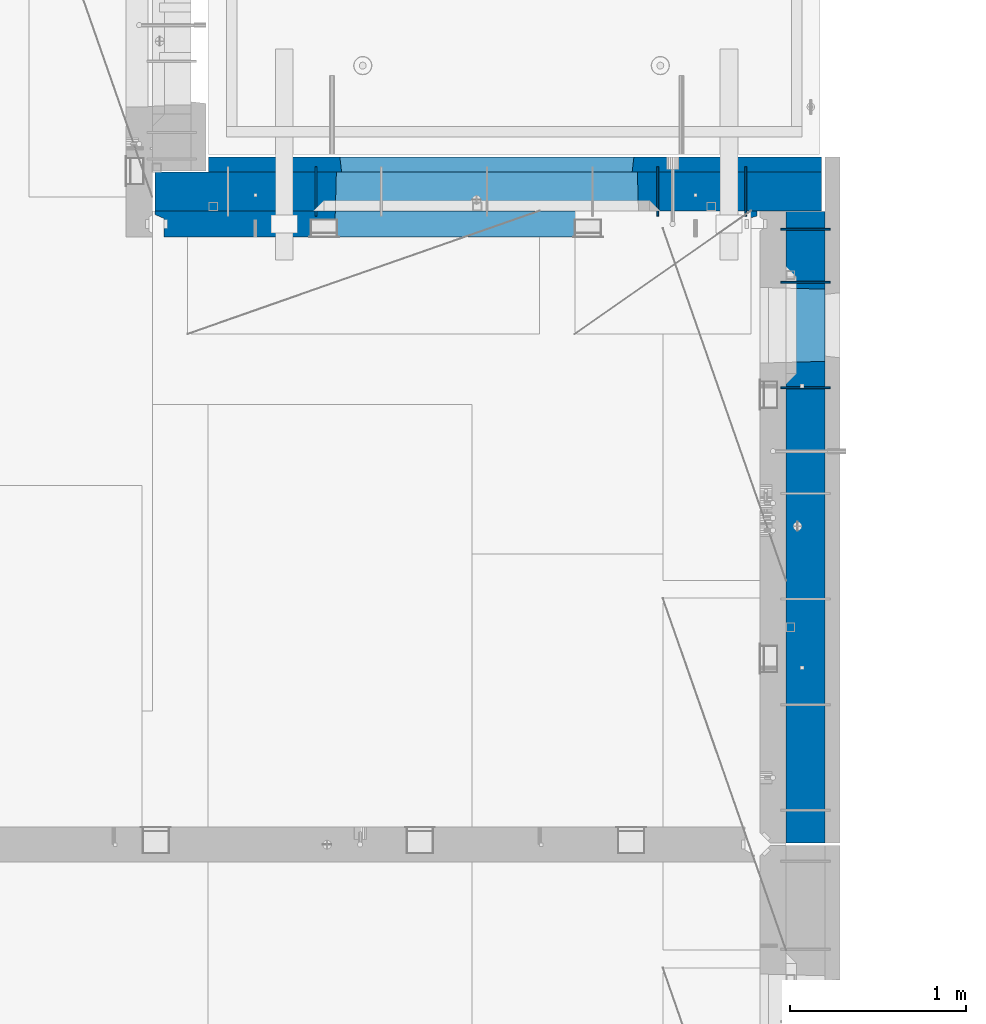
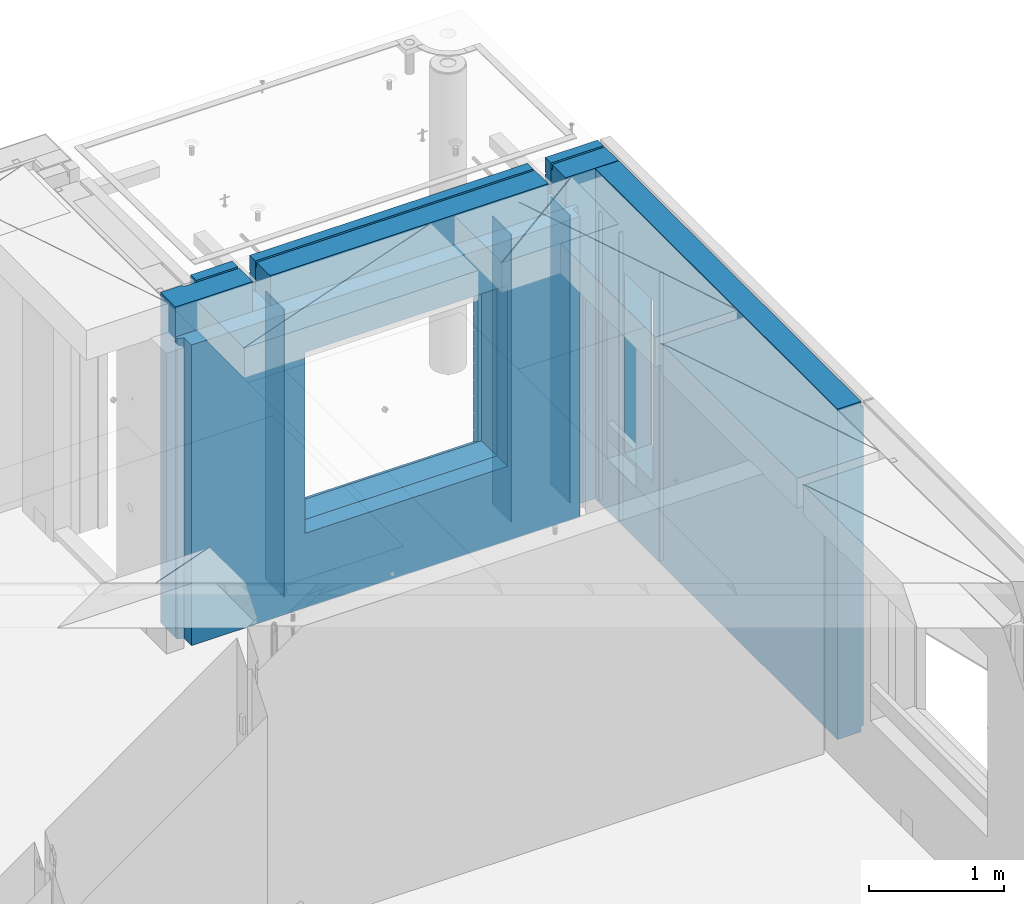
# One storey, part 222 of 325: 10 walls, 2 elements without a shape of their own.
"""IFC2X3 building model written with IfcOpenShell, lengths in millimetres."""

from ifc_helpers import new_model, si_unit, frame, origin_with_axes, place, context, subcontext, project, spatial, faceted_brep, material, type_object, element, aggregate, save


model = new_model("IFC2X3")

# Units and contexts
model_context = context("Model", 3, precision=1e-05, world=origin_with_axes())
body_context = subcontext(model_context, "Body", "Model", "MODEL_VIEW")
ifc_project = project(units=[si_unit("LENGTHUNIT", "METRE", prefix="MILLI"), si_unit("AREAUNIT", "SQUARE_METRE"), si_unit("VOLUMEUNIT", "CUBIC_METRE"), si_unit("MASSUNIT", "GRAM", prefix="KILO"), si_unit("TIMEUNIT", "SECOND"), si_unit("PLANEANGLEUNIT", "RADIAN"), si_unit("SOLIDANGLEUNIT", "STERADIAN"), si_unit("THERMODYNAMICTEMPERATUREUNIT", "DEGREE_CELSIUS"), si_unit("LUMINOUSINTENSITYUNIT", "LUMEN")], contexts=[model_context])

# Site, building, storey
site_placement = place(None, origin_with_axes())
site = spatial("IfcSite", under=ifc_project, at=site_placement, CompositionType="ELEMENT")
building_placement = place(site_placement, origin_with_axes())
building = spatial("IfcBuilding", under=site, at=building_placement, CompositionType="ELEMENT")
storey_placement = place(building_placement, origin_with_axes())
storey = spatial("IfcBuildingStorey", under=building, at=storey_placement, Name="1", CompositionType="ELEMENT", Elevation=0.0)

# Assembly, walls
assembly_1_placement = place(storey_placement, origin_with_axes())
assembly_1 = element("IfcElementAssembly", 1, at=assembly_1_placement, inside=storey, AssemblyPlace="NOTDEFINED", PredefinedType="REINFORCEMENT_UNIT")
ifc_material_1 = material(Name="Undefined")
wall_type_1 = type_object("IfcWallType", PredefinedType="NOTDEFINED")
wall_1_placement = place(assembly_1_placement, frame((34830.0, 20549.9951872276, 83115.0), z_axis=(0.0, 0.0, 1.0), x_axis=(0.0, 1.0, 0.0)))
wall_1 = element("IfcWall", 2, at=wall_1_placement, type_object=wall_type_1, material=ifc_material_1, Name="(PD)", context=body_context, shape_type="Brep", body=[
    faceted_brep([(0.0, 5.0, -1300.0), (0.0, 5.0, 1300.0), (280.0, 5.0, 1300.0), (280.0, 5.0, -1300.0), (0.0, -5.0, 1300.0), (280.0, -5.0, 1300.0), (0.0, -5.0, -1300.0), (280.0, -5.0, -1300.0)], [[[0, 1, 2, 3]], [[1, 4, 5, 2]], [[4, 6, 7, 5]], [[6, 0, 3, 7]], [[5, 7, 3, 2]], [[6, 4, 1, 0]]]),
])
wall_2_placement = place(assembly_1_placement, frame((34330.0, 20549.9951872276, 83115.0), z_axis=(0.0, 0.0, 1.0), x_axis=(0.0, 1.0, 0.0)))
wall_2 = element("IfcWall", 3, at=wall_2_placement, type_object=wall_type_1, material=ifc_material_1, Name="(PD)", context=body_context, shape_type="Brep", body=[
    faceted_brep([(0.0, 5.0, -1300.0), (0.0, 5.0, 1300.0), (280.0, 5.0, 1300.0), (280.0, 5.0, -1300.0), (0.0, -5.0, 1300.0), (280.0, -5.0, 1300.0), (0.0, -5.0, -1300.0), (280.0, -5.0, -1300.0)], [[[0, 1, 2, 3]], [[1, 4, 5, 2]], [[4, 6, 7, 5]], [[6, 0, 3, 7]], [[5, 7, 3, 2]], [[6, 4, 1, 0]]]),
])
wall_3_placement = place(assembly_1_placement, frame((32390.0, 20549.9951872276, 83115.0), z_axis=(0.0, 0.0, 1.0), x_axis=(0.0, 1.0, 0.0)))
wall_3 = element("IfcWall", 4, at=wall_3_placement, type_object=wall_type_1, material=ifc_material_1, Name="(PD)", context=body_context, shape_type="Brep", body=[
    faceted_brep([(0.0, 5.0, -1300.0), (0.0, 5.0, 1300.0), (280.0, 5.0, 1300.0), (280.0, 5.0, -1300.0), (0.0, -5.0, 1300.0), (280.0, -5.0, 1300.0), (0.0, -5.0, -1300.0), (280.0, -5.0, -1300.0)], [[[0, 1, 2, 3]], [[1, 4, 5, 2]], [[4, 6, 7, 5]], [[6, 0, 3, 7]], [[5, 7, 3, 2]], [[6, 4, 1, 0]]]),
])

assembly_2_placement = place(storey_placement, origin_with_axes())
assembly_2 = element("IfcElementAssembly", 5, at=assembly_2_placement, inside=storey, AssemblyPlace="NOTDEFINED", PredefinedType="REINFORCEMENT_UNIT")
wall_4_placement = place(assembly_2_placement, frame((35030.0, 20175.0002441406, 83115.0), z_axis=(0.0, 0.0, 1.0), x_axis=(1.0, 0.0, 0.0)))
wall_4 = element("IfcWall", 6, at=wall_4_placement, type_object=wall_type_1, material=ifc_material_1, Name="(PD)", context=body_context, shape_type="Brep", body=[
    faceted_brep([(0.0, 5.0, -1300.0), (0.0, 5.0, 1300.0), (280.0, 5.0, 1300.0), (280.0, 5.0, -1300.0), (0.0, -5.0, 1300.0), (280.0, -5.0, 1300.0), (0.0, -5.0, -1300.0), (280.0, -5.0, -1300.0)], [[[0, 1, 2, 3]], [[1, 4, 5, 2]], [[4, 6, 7, 5]], [[6, 0, 3, 7]], [[5, 7, 3, 2]], [[6, 4, 1, 0]]]),
])
wall_5_placement = place(assembly_2_placement, frame((35030.0, 20475.0002441406, 83115.0), z_axis=(0.0, 0.0, 1.0), x_axis=(1.0, 0.0, 0.0)))
wall_5 = element("IfcWall", 7, at=wall_5_placement, type_object=wall_type_1, material=ifc_material_1, Name="(PD)", context=body_context, shape_type="Brep", body=[
    faceted_brep([(0.0, 5.0, -1300.0), (0.0, 5.0, 1300.0), (280.0, 5.0, 1300.0), (280.0, 5.0, -1300.0), (0.0, -5.0, 1300.0), (280.0, -5.0, 1300.0), (0.0, -5.0, -1300.0), (280.0, -5.0, -1300.0)], [[[0, 1, 2, 3]], [[1, 4, 5, 2]], [[4, 6, 7, 5]], [[6, 0, 3, 7]], [[5, 7, 3, 2]], [[6, 4, 1, 0]]]),
])
wall_6_placement = place(assembly_2_placement, frame((35030.0, 19575.0002441406, 83115.0), z_axis=(0.0, 0.0, 1.0), x_axis=(1.0, 0.0, 0.0)))
wall_6 = element("IfcWall", 8, at=wall_6_placement, type_object=wall_type_1, material=ifc_material_1, Name="(PD)", context=body_context, shape_type="Brep", body=[
    faceted_brep([(0.0, 5.0, -1300.0), (0.0, 5.0, 1300.0), (280.0, 5.0, 1300.0), (280.0, 5.0, -1300.0), (0.0, -5.0, 1300.0), (280.0, -5.0, 1300.0), (0.0, -5.0, -1300.0), (280.0, -5.0, -1300.0)], [[[0, 1, 2, 3]], [[1, 4, 5, 2]], [[4, 6, 7, 5]], [[6, 0, 3, 7]], [[5, 7, 3, 2]], [[6, 4, 1, 0]]]),
])
ifc_material_2 = material(Name="COS5gt")
wall_type_2 = type_object("IfcWallType", PredefinedType="NOTDEFINED")
wall_7_placement = place(assembly_2_placement, frame((35170.0, 20575.0002441406, 83247.5), z_axis=(0.0, 0.0, 1.0), x_axis=(0.0, -1.0, 0.0)))
wall_7 = element("IfcWall", 9, at=wall_7_placement, type_object=wall_type_2, material=ifc_material_2, context=body_context, shape_type="Brep", body=[
    faceted_brep([(0.0, 90.0, 1492.5), (3585.0, 90.0, 1492.5), (3585.0, 90.0, 1442.5), (0.0, 90.0, 1442.5), (0.0, -110.0, 1492.5), (3585.0, -110.0, 1492.5), (3585.0, 110.0, 1442.5), (3585.0, -110.0, -1492.5), (3585.0, 90.0, -1492.5), (3585.0, 90.0, -1442.5), (3585.0, 110.0, -1442.5), (0.0, 110.0, 1442.5), (0.0, 90.0, -1492.5), (0.0, -110.0, -1492.5), (0.0, 110.0, -1442.5), (0.0, 90.0, -1442.5), (440.000277665298, 110.0, -807.5), (470.000277665298, 110.0, -807.5), (820.000277665298, 110.0, -807.5), (850.000277665298, 110.0, -807.5), (850.000277665298, 110.0, -802.5), (850.000277665298, 110.0, 807.5), (440.000277665298, 110.0, 807.5), (440.000277665298, 110.0, -802.5), (855.946223611245, -110.0, -813.445945945947), (855.946223611245, -110.0, 813.445945945947), (434.054331719351, -110.0, -813.445945945947), (434.054331719351, -110.0, 813.445945945947)], [[[0, 1, 2, 3]], [[4, 5, 1, 0]], [[6, 2, 1, 5, 7, 8, 9, 10]], [[11, 3, 2, 6]], [[12, 13, 4, 0, 3, 11, 14, 15]], [[7, 13, 12, 8]], [[15, 9, 8, 12]], [[14, 10, 9, 15]], [[11, 6, 10, 14], [16, 17, 18, 19, 20, 21, 22, 23]], [[20, 19, 24, 25, 21]], [[18, 17, 16, 26, 24, 19]], [[23, 22, 27, 26, 16]], [[21, 25, 27, 22]], [[4, 13, 7, 5], [24, 26, 27, 25]]]),
])
aggregate(assembly_2, [wall_4, wall_5, wall_6, wall_7])

# Wall
wall_8_placement = place(assembly_1_placement, frame((31475.0, 20689.9951872276, 83247.5), z_axis=(0.0, 0.0, 1.0), x_axis=(1.0, 0.0, 0.0)))
wall_8 = element("IfcWall", 10, at=wall_8_placement, type_object=wall_type_2, material=ifc_material_2, context=body_context, shape_type="Brep", body=[
    faceted_brep([(810.0, 110.0, 1442.5), (810.0, 90.0, 1442.5), (3185.0, 90.0, 1442.5), (3185.0, 110.0, 1442.5), (810.0, 90.0, 1492.5), (810.0, -110.0, 1492.5), (3185.0, -110.0, 1492.5), (3185.0, 90.0, 1492.5), (184.0, 90.0, 1442.5), (184.0, 90.0, 1492.5), (660.0, 90.0, 1492.5), (660.0, 90.0, 1442.5), (184.0, 110.0, 1492.5), (184.0, 110.0, 1442.5), (0.0, 110.0, 1492.5), (0.0, -110.0, 1492.5), (660.0, -110.0, 1492.5), (0.0, -110.0, -1492.5), (0.0, 110.0, -1492.5), (3785.0, 90.0, -1492.5), (184.0, 90.0, -1492.5), (184.0, 90.0, -1442.5), (3785.0, 90.0, -1442.5), (3785.0, -110.0, -1492.5), (184.0, 110.0, -1492.5), (184.0, 110.0, -1442.5), (3785.0, 110.0, -1442.5), (3785.0, 110.0, 1442.5), (3785.0, 90.0, 1442.5), (3785.0, 90.0, 1492.5), (3785.0, -110.0, 1492.5), (3335.0, 90.0, 1492.5), (3335.0, -110.0, 1492.5), (3185.0, -110.000000000004, 1222.5), (810.0, -110.0, 1222.5), (660.0, -110.0, 1222.5), (3335.0, -110.000000000004, 1222.5), (1024.05429979644, -110.000000000004, -813.445945945947), (1024.05429979644, -110.000000000004, 813.445945945947), (2745.94619168834, -110.000000000004, 813.445945945947), (2745.94619168834, -110.000000000004, -813.445945945947), (1030.00024574239, 110.0, -802.5), (1030.00024574239, 110.0, 807.5), (1030.00024574239, 110.0, -807.5), (2740.00024574239, 110.0, -807.5), (2710.00024574239, 110.0, -807.5), (1060.00024574239, 110.0, -807.5), (2740.00024574239, 110.0, 807.5), (2740.00024574239, 110.0, -802.5), (660.0, 110.0, 1442.5), (660.0, 109.999999999996, 1222.5), (810.0, 109.999999999996, 1222.5), (3185.0, 109.999999999996, 1222.5), (3335.0, 109.999999999996, 1222.5), (3335.0, 110.0, 1442.5), (3335.0, 90.0, 1442.5)], [[[0, 1, 2, 3]], [[4, 5, 6, 7]], [[8, 9, 10, 11]], [[12, 9, 8, 13]], [[9, 12, 14, 15, 16, 10]], [[17, 15, 14, 18]], [[19, 20, 21, 22]], [[23, 17, 18, 24, 20, 19]], [[25, 21, 20, 24]], [[26, 22, 21, 25]], [[27, 28, 29, 30, 23, 19, 22, 26]], [[30, 29, 31, 32]], [[33, 6, 5, 34, 35, 16, 15, 17, 23, 30, 32, 36], [37, 38, 39, 40]], [[41, 42, 38, 37, 43]], [[40, 44, 45, 46, 43, 37]], [[39, 47, 48, 44, 40]], [[38, 42, 47, 39]], [[27, 26, 25, 24, 18, 14, 12, 13, 49, 50, 51, 0, 3, 52, 53, 54], [41, 43, 46, 45, 44, 48, 47, 42]], [[28, 27, 54, 55]], [[29, 28, 55, 31]], [[54, 53, 36, 32, 31, 55]], [[52, 33, 36, 53]], [[3, 2, 7, 6, 33, 52]], [[1, 4, 7, 2]], [[0, 51, 34, 5, 4, 1]], [[50, 35, 34, 51]], [[49, 11, 10, 16, 35, 50]], [[13, 8, 11, 49]]]),
])

ifc_material_3 = material(Name="CONCRETE/C30/37")
wall_type_3 = type_object("IfcWallType", PredefinedType="NOTDEFINED")
wall_9_placement = place(assembly_1_placement, frame((31780.0, 20842.4951872276, 83247.5), z_axis=(0.0, 0.0, 1.0), x_axis=(1.0, 0.0, 0.0)))
wall_9 = element("IfcWall", 11, at=wall_9_placement, type_object=wall_type_3, material=ifc_material_3, context=body_context, shape_type="Brep", body=[
    faceted_brep([(3480.0, -42.5, 1492.5), (3480.0, 42.5, 1492.5), (3030.0, 42.5, 1492.5), (3030.0, -42.5, 1492.5), (3480.0, 42.4999992431694, 1356.99999988925), (3030.0, 42.4999993410347, 1356.99999988925), (3480.0, 32.4999991127006, 1355.00000040044), (3480.0, 32.4999992507037, 1344.99999999926), (3030.0, 32.4999992507037, 1344.99999999926), (3030.0, 32.4999991127006, 1355.00000040044), (3480.0, 42.4999996036895, 1342.99999994476), (3030.0, 42.4999996549377, 1342.99999994476), (3480.0, 42.4999993831152, 892.999999944761), (0.0, 42.5, 892.999999944761), (0.0, 32.4999992507037, 894.999999999258), (3480.0, 32.4999992507037, 894.999999999258), (0.0, 32.4999991127006, 905.00000040044), (3480.0, 32.4999991127006, 905.00000040044), (3480.0, 42.4999992431694, 906.999999889245), (0.0, 42.5, 906.999999889245), (0.0, 42.5, 1042.99999994476), (3480.0, 42.4999994189675, 1042.99999994476), (0.0, 32.4999992507037, 1044.99999999926), (3480.0, 32.4999992507037, 1044.99999999926), (0.0, 32.4999991127006, 1055.00000040044), (3480.0, 32.4999991127006, 1055.00000040044), (3480.0, 42.4999992431694, 1056.99999988925), (0.0, 42.5, 1056.99999988925), (0.0, 42.5, 1192.99999994476), (3480.0, 42.4999994795144, 1192.99999994476), (0.0, 32.4999992507037, 1194.99999999926), (3480.0, 32.4999992507037, 1194.99999999926), (0.0, 32.4999991127006, 1205.00000040044), (3480.0, 32.4999991127006, 1205.00000040044), (3480.0, 42.4999992431694, 1206.99999988925), (0.0, 42.5, 1206.99999988925), (-3.63797880709171e-12, 32.4999992507037, 1344.99999999926), (-3.63797880709171e-12, 32.4999991127006, 1355.00000040044), (355.0, 32.4999991127006, 1355.00000040044), (355.0, 32.4999992507037, 1344.99999999926), (0.0, 42.5, 1342.99999994476), (355.0, 42.4999999595711, 1342.99999994476), (505.0, 32.4999992507037, 1344.99999999926), (505.0, 32.4999991127006, 1355.00000040044), (2880.0, 32.4999991127006, 1355.00000040044), (2880.0, 32.4999992507037, 1344.99999999926), (505.0, 42.4999999424908, 1342.99999994476), (2880.0, 42.4999996720217, 1342.99999994476), (355.0, 42.4999998715975, 1222.5), (505.0, 42.4999998467429, 1222.5), (2880.0, 42.4999994331811, 1222.5), (3030.0, 42.4999994081736, 1222.5), (355.0, -42.5, 1222.5), (505.0, -42.5, 1222.5), (505.0, 42.5, 1492.5), (505.0, 42.4999998901731, 1356.99999988925), (505.0, -42.5, 1492.5), (2880.0, -42.5, 1492.5), (2880.0, 42.5, 1492.5), (2880.0, 42.4999993736565, 1356.99999988925), (2880.0, -42.5000000000036, 1222.5), (3030.0, -42.5000000000036, 1222.5), (3480.0, -42.5, -1492.5), (3480.0, 42.5, -1492.5), (3480.0, 42.5, -1357.00000005524), (3480.0, 32.4999992507037, -1355.00000000074), (3480.0, 32.4999991127006, -1344.99999959956), (3480.0, 42.4999992431694, -1343.00000011075), (3480.0, 42.4999992794692, -1207.00000005524), (3480.0, 32.4999992507037, -1205.00000000074), (3480.0, 32.4999991127006, -1194.99999959956), (3480.0, 42.4999992431694, -1193.00000011075), (3480.0, 42.4999992814955, -1057.00000005524), (3480.0, 32.4999992507037, -1055.00000000074), (3480.0, 32.4999991127006, -1044.99999959956), (3480.0, 42.4999992431694, -1043.00000011075), (3480.0, 42.4999992837656, -907.000000055239), (3480.0, 32.4999992507037, -905.000000000742), (3480.0, 32.4999991127006, -894.99999959956), (3480.0, 42.4999992431694, -893.000000110755), (3480.0, 42.4999992863159, -757.000000055239), (3480.0, 32.4999992507037, -755.000000000742), (3480.0, 32.4999991127006, -744.99999959956), (3480.0, 42.4999992431694, -743.000000110755), (3480.0, 42.4999992892117, -607.000000055239), (3480.0, 32.4999992507037, -605.000000000742), (3480.0, 32.4999991127006, -594.99999959956), (3480.0, 42.4999992431694, -593.000000110755), (3480.0, 42.4999992925223, -457.000000055239), (3480.0, 32.4999992507037, -455.000000000742), (3480.0, 32.4999991127006, -444.99999959956), (3480.0, 42.4999992431694, -443.000000110755), (3480.0, 42.4999992963494, -307.000000055239), (3480.0, 32.4999992507037, -305.000000000742), (3480.0, 32.4999991127006, -294.99999959956), (3480.0, 42.4999992431694, -293.000000110755), (3480.0, 42.4999993008169, -157.000000055239), (3480.0, 32.4999992507037, -155.000000000742), (3480.0, 32.4999991127006, -144.99999959956), (3480.0, 42.4999992431694, -143.000000110755), (3480.0, 42.4999993061028, -7.00000005523907), (3480.0, 32.4999992507037, -5.00000000074215), (3480.0, 32.4999991127006, 5.0000004004396), (3480.0, 42.4999992431694, 6.99999988924537), (3480.0, 42.4999993124584, 142.999999944761), (3480.0, 32.4999992507037, 144.999999999258), (3480.0, 32.4999991127006, 155.00000040044), (3480.0, 42.4999992431694, 156.999999889245), (3480.0, 42.49999932024, 292.999999944761), (3480.0, 32.4999992507037, 294.999999999258), (3480.0, 32.4999991127006, 305.00000040044), (3480.0, 42.4999992431694, 306.999999889245), (3480.0, 42.4999993299934, 442.999999944761), (3480.0, 32.4999992507037, 444.999999999258), (3480.0, 32.4999991127006, 455.00000040044), (3480.0, 42.4999992431694, 456.999999889245), (3480.0, 42.4999993425699, 592.999999944761), (3480.0, 32.4999992507037, 594.999999999258), (3480.0, 32.4999991127006, 605.00000040044), (3480.0, 42.4999992431694, 606.999999889245), (3480.0, 42.4999993594065, 742.999999944761), (3480.0, 32.4999992507037, 744.999999999258), (3480.0, 32.4999991127006, 755.00000040044), (3480.0, 42.4999992431694, 756.999999889245), (0.0, -42.5, -1492.5), (0.0, 42.5, -1492.5), (0.0, 42.5, -1357.00000005524), (0.0, 32.4999992507037, -1355.00000000074), (0.0, 32.4999991127006, -1344.99999959956), (0.0, 42.5, -1343.00000011075), (0.0, 42.5, -1207.00000005524), (0.0, 32.4999992507037, -1205.00000000074), (0.0, 32.4999991127006, -1194.99999959956), (0.0, 42.5, -1193.00000011075), (0.0, 42.5, -1057.00000005524), (0.0, 32.4999992507037, -1055.00000000074), (0.0, 32.4999991127006, -1044.99999959956), (0.0, 42.5, -1043.00000011075), (0.0, 42.5, -907.000000055239), (0.0, 32.4999992507037, -905.000000000742), (0.0, 32.4999991127006, -894.99999959956), (0.0, 42.5, -893.000000110755), (0.0, 32.4999991127006, 755.00000040044), (0.0, 42.5, 756.999999889245), (745.000245742391, 42.4999998379753, 756.999999889245), (746.176716435013, 32.4999991127006, 755.00000040044), (0.0, 32.4999992507037, 744.999999999258), (746.17671641878, 32.4999992507037, 744.999999999258), (0.0, 42.5, 742.999999944761), (745.000245742391, 42.4999998628628, 742.999999944761), (0.0, 42.5, 606.999999889245), (745.000245742391, 42.4999998379753, 606.999999889245), (3.63797880709171e-12, 32.4999991127006, 605.00000040044), (746.176716435013, 32.4999991127006, 605.00000040044), (3.63797880709171e-12, 32.4999992507037, 594.999999999258), (746.176716418777, 32.4999992507037, 594.999999999258), (0.0, 42.5, 592.999999944761), (745.000245742391, 42.4999998592575, 592.999999944761), (0.0, 42.5, 456.999999889245), (745.000245742391, 42.4999998379753, 456.999999889245), (0.0, 32.4999991127006, 455.00000040044), (746.176716435013, 32.4999991127006, 455.00000040044), (0.0, 32.4999992507037, 444.999999999258), (746.17671641878, 32.4999992507037, 444.999999999258), (0.0, 42.5, 442.999999944761), (745.000245742391, 42.4999998565654, 442.999999944761), (0.0, 42.5, 306.999999889245), (745.000245742391, 42.4999998379753, 306.999999889245), (-3.63797880709171e-12, 32.4999991127006, 305.00000040044), (746.176716435013, 32.4999991127006, 305.00000040044), (-3.63797880709171e-12, 32.4999992507037, 294.999999999258), (746.176716418777, 32.4999992507037, 294.999999999258), (0.0, 42.5, 292.999999944761), (745.000245742391, 42.4999998544772, 292.999999944761), (0.0, 42.5, 156.999999889245), (745.000245742391, 42.4999998379753, 156.999999889245), (-3.63797880709171e-12, 32.4999991127006, 155.00000040044), (746.176716435013, 32.4999991127006, 155.00000040044), (-3.63797880709171e-12, 32.4999992507037, 144.999999999258), (746.176716418777, 32.4999992507037, 144.999999999258), (0.0, 42.5, 142.999999944761), (745.000245742391, 42.499999852811, 142.999999944761), (0.0, 42.5, 6.99999988924537), (745.000245742391, 42.4999998379753, 6.99999988924537), (0.0, 32.4999991127006, 5.0000004004396), (746.176716435013, 32.4999991127006, 5.0000004004396), (0.0, 32.4999992507037, -5.00000000074215), (746.17671641878, 32.4999992507037, -5.00000000074215), (0.0, 42.5, -7.00000005523907), (745.000245742391, 42.4999998514504, -7.00000005523907), (0.0, 42.5, -143.000000110755), (745.000245742391, 42.4999998379753, -143.000000110755), (3.63797880709171e-12, 32.4999991127006, -144.99999959956), (746.176716435013, 32.4999991127006, -144.99999959956), (3.63797880709171e-12, 32.4999992507037, -155.000000000742), (746.176716418777, 32.4999992507037, -155.000000000742), (0.0, 42.5, -157.000000055239), (745.000245742391, 42.499999850319, -157.000000055239), (0.0, 42.5, -293.000000110755), (745.000245742391, 42.4999998379753, -293.000000110755), (0.0, 32.4999991127006, -294.99999959956), (746.176716435013, 32.4999991127006, -294.99999959956), (0.0, 32.4999992507037, -305.000000000742), (746.17671641878, 32.4999992507037, -305.000000000742), (0.0, 42.5, -307.000000055239), (745.000245742391, 42.4999998493622, -307.000000055239), (0.0, 42.5, -443.000000110755), (745.000245742391, 42.4999998379753, -443.000000110755), (0.0, 32.4999991127006, -444.99999959956), (746.176716435013, 32.4999991127006, -444.99999959956), (0.0, 32.4999992507037, -455.000000000742), (746.17671641878, 32.4999992507037, -455.000000000742), (0.0, 42.5, -457.000000055239), (745.000245742391, 42.4999998485437, -457.000000055239), (0.0, 42.5, -593.000000110755), (745.000245742391, 42.4999998379753, -593.000000110755), (3.63797880709171e-12, 32.4999991127006, -594.99999959956), (746.176716435013, 32.4999991127006, -594.99999959956), (3.63797880709171e-12, 32.4999992507037, -605.000000000742), (746.176716418777, 32.4999992507037, -605.000000000742), (0.0, 42.5, -607.000000055239), (745.000245742391, 42.4999998478343, -607.000000055239), (0.0, 42.5, -743.000000110755), (745.000245742391, 42.4999998379753, -743.000000110755), (0.0, 32.4999991127006, -744.99999959956), (746.176716435013, 32.4999991127006, -744.99999959956), (0.0, 32.4999992507037, -755.000000000742), (746.17671641878, 32.4999992507037, -755.000000000742), (0.0, 42.5, -757.000000055239), (745.000245742391, 42.4999998472158, -757.000000055239), (745.000245742391, 42.5, -857.5), (755.000245742391, -42.5, -807.5), (2405.00024574239, -42.5, -807.5), (2415.00024574239, 42.5, -857.5), (2415.00024574239, 42.4999995047292, -757.000000055239), (2413.823775066, 32.4999992507037, -755.000000000742), (2413.82377504977, 32.4999991127006, -744.99999959956), (2415.00024574239, 42.499999474785, -743.000000110755), (2415.00024574239, 42.4999995067374, -607.000000055239), (2413.823775066, 32.4999992507037, -605.000000000742), (2413.82377504977, 32.4999991127006, -594.99999959956), (2415.00024574239, 42.499999474785, -593.000000110755), (2415.00024574239, 42.4999995090366, -457.000000055239), (2413.823775066, 32.4999992507037, -455.000000000742), (2413.82377504977, 32.4999991127006, -444.99999959956), (2415.00024574239, 42.499999474785, -443.000000110755), (2415.00024574239, 42.4999995116923, -307.000000055239), (2413.823775066, 32.4999992507037, -305.000000000742), (2413.82377504977, 32.4999991127006, -294.99999959956), (2415.00024574239, 42.499999474785, -293.000000110755), (2415.00024574239, 42.4999995147919, -157.000000055239), (2413.823775066, 32.4999992507037, -155.000000000742), (2413.82377504977, 32.4999991127006, -144.99999959956), (2415.00024574239, 42.499999474785, -143.000000110755), (2415.00024574239, 42.4999995184589, -7.00000005523907), (2413.823775066, 32.4999992507037, -5.00000000074215), (2413.82377504977, 32.4999991127006, 5.0000004004396), (2415.00024574239, 42.499999474785, 6.99999988924537), (2415.00024574239, 42.4999995228682, 142.999999944761), (2413.823775066, 32.4999992507037, 144.999999999258), (2413.82377504977, 32.4999991127006, 155.00000040044), (2415.00024574239, 42.499999474785, 156.999999889245), (2415.00024574239, 42.4999995282706, 292.999999944761), (2413.823775066, 32.4999992507037, 294.999999999258), (2413.82377504977, 32.4999991127006, 305.00000040044), (2415.00024574239, 42.499999474785, 306.999999889245), (2415.00024574239, 42.4999995350372, 442.999999944761), (2413.823775066, 32.4999992507037, 444.999999999258), (2413.82377504977, 32.4999991127006, 455.00000040044), (2415.00024574239, 42.499999474785, 456.999999889245), (2415.00024574239, 42.4999995437647, 592.999999944761), (2413.823775066, 32.4999992507037, 594.999999999258), (2413.82377504977, 32.4999991127006, 605.00000040044), (2415.00024574239, 42.499999474785, 606.999999889245), (2415.00024574239, 42.4999995554499, 742.999999944761), (2413.823775066, 32.4999992507037, 744.999999999258), (2413.82377504977, 32.4999991127006, 755.00000040044), (2415.00024574239, 42.499999474785, 756.999999889245), (755.000245742391, 42.5, 782.5), (745.000245742391, 42.5, 782.5), (2415.00024574239, 42.5, 782.5), (2405.00024574239, 42.5, 782.5), (755.000245742391, -42.5, 782.5), (755.000245742391, -42.5, 787.5), (2405.00024574239, -42.5, 787.5), (2405.00024574239, -42.5, 782.5), (355.0, -42.5, 1492.5), (0.0, -42.5, 1492.5), (0.0, 42.5, 1492.5), (355.0, 42.5, 1492.5), (0.0, 42.5, 1356.99999988925), (355.0, 42.4999999227948, 1356.99999988925)], [[[0, 1, 2, 3]], [[1, 4, 5, 2]], [[6, 7, 8, 9]], [[7, 10, 11, 8]], [[12, 13, 14, 15]], [[15, 14, 16, 17]], [[18, 17, 16, 19]], [[18, 19, 20, 21]], [[21, 20, 22, 23]], [[23, 22, 24, 25]], [[26, 25, 24, 27]], [[26, 27, 28, 29]], [[29, 28, 30, 31]], [[31, 30, 32, 33]], [[34, 33, 32, 35]], [[36, 37, 38, 39]], [[40, 36, 39, 41]], [[42, 43, 44, 45]], [[46, 42, 45, 47]], [[10, 34, 35, 40, 41, 48, 49, 46, 47, 50, 51, 11]], [[48, 52, 53, 49]], [[54, 55, 43, 42, 46, 49, 53, 56]], [[54, 56, 57, 58]], [[55, 54, 58, 59]], [[43, 55, 59, 44]], [[58, 57, 60, 50, 47, 45, 44, 59]], [[50, 60, 61, 51]], [[2, 5, 9, 8, 11, 51, 61, 3]], [[4, 6, 9, 5]], [[1, 0, 62, 63, 64, 65, 66, 67, 68, 69, 70, 71, 72, 73, 74, 75, 76, 77, 78, 79, 80, 81, 82, 83, 84, 85, 86, 87, 88, 89, 90, 91, 92, 93, 94, 95, 96, 97, 98, 99, 100, 101, 102, 103, 104, 105, 106, 107, 108, 109, 110, 111, 112, 113, 114, 115, 116, 117, 118, 119, 120, 121, 122, 123, 12, 15, 17, 18, 21, 23, 25, 26, 29, 31, 33, 34, 10, 7, 6, 4]], [[124, 125, 63, 62]], [[63, 125, 126, 64]], [[64, 126, 127, 65]], [[65, 127, 128, 66]], [[67, 66, 128, 129]], [[67, 129, 130, 68]], [[68, 130, 131, 69]], [[69, 131, 132, 70]], [[71, 70, 132, 133]], [[71, 133, 134, 72]], [[72, 134, 135, 73]], [[73, 135, 136, 74]], [[75, 74, 136, 137]], [[75, 137, 138, 76]], [[76, 138, 139, 77]], [[77, 139, 140, 78]], [[79, 78, 140, 141]], [[142, 143, 144, 145]], [[146, 142, 145, 147]], [[148, 146, 147, 149]], [[150, 148, 149, 151]], [[152, 150, 151, 153]], [[154, 152, 153, 155]], [[156, 154, 155, 157]], [[158, 156, 157, 159]], [[160, 158, 159, 161]], [[162, 160, 161, 163]], [[164, 162, 163, 165]], [[166, 164, 165, 167]], [[168, 166, 167, 169]], [[170, 168, 169, 171]], [[172, 170, 171, 173]], [[174, 172, 173, 175]], [[176, 174, 175, 177]], [[178, 176, 177, 179]], [[180, 178, 179, 181]], [[182, 180, 181, 183]], [[184, 182, 183, 185]], [[186, 184, 185, 187]], [[188, 186, 187, 189]], [[190, 188, 189, 191]], [[192, 190, 191, 193]], [[194, 192, 193, 195]], [[196, 194, 195, 197]], [[198, 196, 197, 199]], [[200, 198, 199, 201]], [[202, 200, 201, 203]], [[204, 202, 203, 205]], [[206, 204, 205, 207]], [[208, 206, 207, 209]], [[210, 208, 209, 211]], [[212, 210, 211, 213]], [[214, 212, 213, 215]], [[216, 214, 215, 217]], [[218, 216, 217, 219]], [[220, 218, 219, 221]], [[222, 220, 221, 223]], [[224, 222, 223, 225]], [[226, 224, 225, 227]], [[228, 226, 227, 229]], [[230, 231, 232, 233]], [[80, 79, 141, 228, 229, 230, 233, 234]], [[81, 80, 234, 235]], [[82, 81, 235, 236]], [[83, 82, 236, 237]], [[84, 83, 237, 238]], [[85, 84, 238, 239]], [[86, 85, 239, 240]], [[87, 86, 240, 241]], [[88, 87, 241, 242]], [[89, 88, 242, 243]], [[90, 89, 243, 244]], [[91, 90, 244, 245]], [[92, 91, 245, 246]], [[93, 92, 246, 247]], [[94, 93, 247, 248]], [[95, 94, 248, 249]], [[96, 95, 249, 250]], [[97, 96, 250, 251]], [[98, 97, 251, 252]], [[99, 98, 252, 253]], [[100, 99, 253, 254]], [[101, 100, 254, 255]], [[102, 101, 255, 256]], [[103, 102, 256, 257]], [[104, 103, 257, 258]], [[105, 104, 258, 259]], [[106, 105, 259, 260]], [[107, 106, 260, 261]], [[108, 107, 261, 262]], [[109, 108, 262, 263]], [[110, 109, 263, 264]], [[111, 110, 264, 265]], [[112, 111, 265, 266]], [[113, 112, 266, 267]], [[114, 113, 267, 268]], [[115, 114, 268, 269]], [[116, 115, 269, 270]], [[117, 116, 270, 271]], [[118, 117, 271, 272]], [[119, 118, 272, 273]], [[120, 119, 273, 274]], [[121, 120, 274, 275]], [[122, 121, 275, 276]], [[123, 122, 276, 277]], [[278, 279, 144, 143, 13, 12, 123, 277, 280, 281]], [[282, 231, 230, 229, 227, 225, 223, 221, 219, 217, 215, 213, 211, 209, 207, 205, 203, 201, 199, 197, 195, 193, 191, 189, 187, 185, 183, 181, 179, 177, 175, 173, 171, 169, 167, 165, 163, 161, 159, 157, 155, 153, 151, 149, 147, 145, 144, 279, 283]], [[278, 281, 280, 284, 283, 279]], [[277, 276, 275, 274, 273, 272, 271, 270, 269, 268, 267, 266, 265, 264, 263, 262, 261, 260, 259, 258, 257, 256, 255, 254, 253, 252, 251, 250, 249, 248, 247, 246, 245, 244, 243, 242, 241, 240, 239, 238, 237, 236, 235, 234, 233, 232, 285, 284, 280]], [[60, 57, 56, 53, 52, 286, 287, 124, 62, 0, 3, 61], [232, 231, 282, 283, 284, 285]], [[288, 287, 286, 289]], [[36, 40, 35, 32, 30, 28, 27, 24, 22, 20, 19, 16, 14, 13, 143, 142, 146, 148, 150, 152, 154, 156, 158, 160, 162, 164, 166, 168, 170, 172, 174, 176, 178, 180, 182, 184, 186, 188, 190, 192, 194, 196, 198, 200, 202, 204, 206, 208, 210, 212, 214, 216, 218, 220, 222, 224, 226, 228, 141, 140, 139, 138, 137, 136, 135, 134, 133, 132, 131, 130, 129, 128, 127, 126, 125, 124, 287, 288, 290, 37]], [[37, 290, 291, 38]], [[289, 286, 52, 48, 41, 39, 38, 291]], [[290, 288, 289, 291]]]),
])

ifc_material_4 = material(Name="CONCRETE/C25/30")
wall_type_4 = type_object("IfcWallType", PredefinedType="NOTDEFINED")
wall_10_placement = place(assembly_1_placement, frame((31475.0, 20504.9951872276, 83112.5), z_axis=(0.0, 0.0, 1.0), x_axis=(1.0, 0.0, 0.0)))
wall_10 = element("IfcWall", 12, at=wall_10_placement, type_object=wall_type_4, material=ifc_material_4, context=body_context, shape_type="Brep", body=[
    faceted_brep([(3370.0, -75.0, 1357.5), (3370.0, -75.0, -1357.5), (3370.0, 32.0, -1357.5), (3370.0, 32.0, 1357.5), (3420.0, 75.0, 1357.5), (0.0, 75.0, 1357.5), (0.0, 53.6645811319431, 1357.5), (49.9951872275633, 32.0, 1357.5), (49.9951872275633, -75.0, 1357.5), (3420.0, 45.0, 1357.5), (49.9951872275633, 32.0, -1357.5), (49.9951872275633, -75.0, -1357.5), (0.0, 53.6645811319431, -1357.5), (0.0, 75.0, -1357.5), (3420.0, 75.0, -1357.5), (3420.0, 45.0, -1357.5), (1020.00024574239, -75.0, 952.5), (1024.05429979644, 75.0, 948.445945945947), (2745.94619168834, 75.0, 948.445945945947), (2750.00024574239, -75.0, 952.5), (1024.05429979644, 75.0, -678.445945945947), (2745.94619168834, 75.0, -678.445945945947), (2750.00024574239, -75.0, -682.5), (1020.00024574239, -75.0, -682.5)], [[[0, 1, 2, 3]], [[4, 5, 6, 7, 8, 0, 3, 9]], [[7, 10, 11, 8]], [[6, 12, 10, 7]], [[5, 13, 12, 6]], [[1, 11, 10, 12, 13, 14, 15, 2]], [[9, 3, 2, 15]], [[14, 4, 9, 15]], [[16, 17, 18, 19]], [[13, 5, 4, 14], [20, 21, 18, 17]], [[19, 18, 21, 22]], [[8, 11, 1, 0], [23, 16, 19, 22]], [[17, 16, 23, 20]], [[22, 21, 20, 23]]]),
])

aggregate(assembly_1, [wall_1, wall_2, wall_3, wall_9, wall_8, wall_10])

save(model, "model.ifc")
